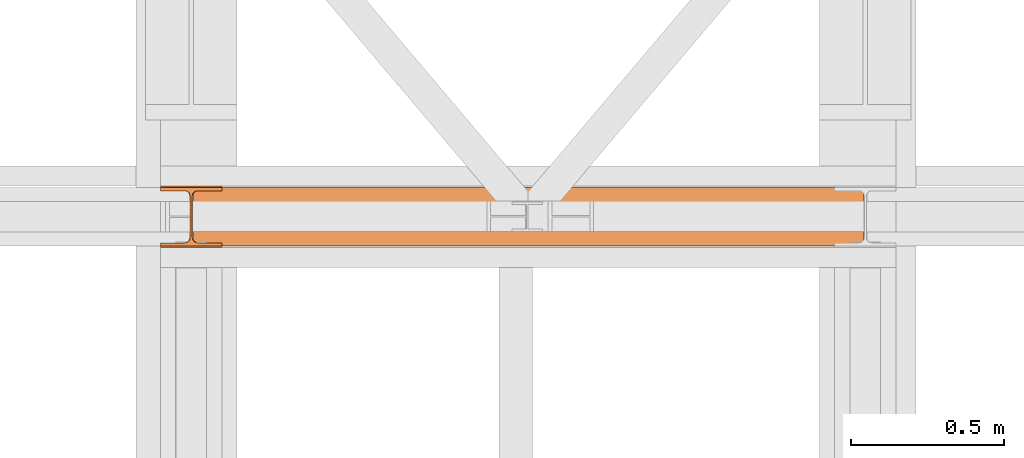
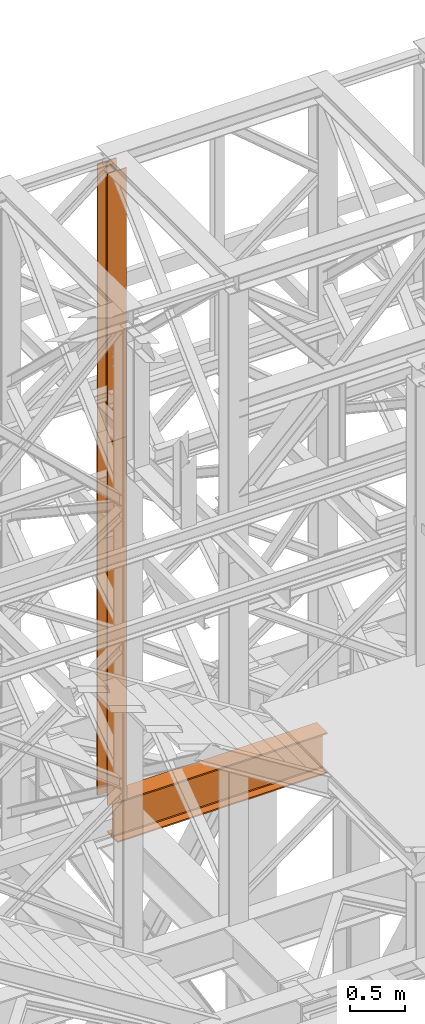
# One storey, part 118 of 208: 3 proxies.
"""IFC2X3 building model written with IfcOpenShell, lengths in millimetres."""

from ifc_helpers import new_model, entity, si_unit, converted_unit, frame, origin, origin_with_axes, place, context, subcontext, project, spatial, faceted_brep, element, save


model = new_model("IFC2X3")

# Units and contexts
model_context = context("Model", 3, precision=1e-05, world=origin())
plan_context = context("Plan", 3, precision=1e-05, world=origin())
body_context = subcontext(model_context, "Body", "Model", "MODEL_VIEW")
ifc_project = project(units=[si_unit("LENGTHUNIT", "METRE", prefix="MILLI"), converted_unit("PLANEANGLEUNIT", "DEGREE", entity("IfcPlaneAngleMeasure", 0.0174532925199433), si_unit("PLANEANGLEUNIT", "RADIAN"), dimensions=[0, 0, 0, 0, 0, 0, 0]), si_unit("AREAUNIT", "SQUARE_METRE"), si_unit("VOLUMEUNIT", "CUBIC_METRE")], contexts=[model_context, plan_context])

# Building, storey
building_placement = place(None, origin())
building = spatial("IfcBuilding", under=ifc_project, at=building_placement, CompositionType="COMPLEX")
storey_placement = place(building_placement, origin_with_axes())
storey = spatial("IfcBuildingStorey", under=building, at=storey_placement, Name="Geschoss", CompositionType="ELEMENT")

# Proxies
proxy_1_placement = place(storey_placement, frame((-0.7450314191753478, -13857.57439657637, 4834.989987483023), z_axis=(0.0, 0.0, 1.0), x_axis=(1.0, 0.0, 0.0)))
element("IfcBuildingElementProxy", 1, at=proxy_1_placement, inside=storey, context=body_context, shape_type="Brep", body=[
    faceted_brep([(2188.009999895692, 0.01000000000021828, 450.0100178813937), (2188.009999895692, 190.0100125169756, 450.0100178813937), (2188.009999895692, 190.0100125169756, 435.4100240564349), (2188.009999895692, 120.7100073045494, 435.4100091552737), (2188.009999895692, 109.841562265754, 433.2347078418734), (2188.009999895692, 101.8853126263621, 425.2784563398363), (2188.009999895692, 99.71000619068764, 414.4100113010409), (2188.009999895692, 99.71000619068764, 35.60999167919181), (2188.009999895692, 101.8853126263621, 24.74154664039634), (2188.009999895692, 109.841562265754, 16.78529513835929), (2188.009999895692, 120.7100073045494, 14.60999382495902), (2188.009999895692, 190.0100125169756, 14.60999382495902), (2188.009999895692, 190.0100125169756, 0.01000000000021828), (2188.009999895692, 0.01000000000021828, 0.01000000000021828), (2188.009999895692, 0.01000000000021828, 14.60999382495902), (2188.009999895692, 69.3100052124264, 14.60999382495902), (2188.009999895692, 80.17845025122188, 16.78529513835929), (2188.009999895692, 88.13469989061377, 24.74154664039634), (2188.009999895692, 90.3100063262882, 35.60999167919181), (2188.009999895692, 90.3100063262882, 414.4100113010409), (2188.009999895692, 88.13469989061377, 425.2784563398363), (2188.009999895692, 80.17845025122188, 433.2347078418734), (2188.009999895692, 69.3100052124264, 435.4100091552737), (2188.009999895692, 0.01000000000021828, 435.4100240564349), (2188.009999895692, 190.0100125169756, 450.0100178813937), (2188.009999895692, 0.01000000000021828, 450.0100178813937), (0.009999999999990905, 0.01000000000021828, 450.0100178813937), (0.009999999999990905, 190.0100125169756, 450.0100178813937), (2188.009999895692, 190.0100125169756, 435.4100240564349), (2188.009999895692, 190.0100125169756, 450.0100178813937), (0.009999999999990905, 190.0100125169756, 450.0100178813937), (0.009999999999990905, 190.0100125169756, 435.4100240564349), (2188.009999895692, 120.7100073045494, 435.4100091552737), (2188.009999895692, 190.0100125169756, 435.4100240564349), (0.009999999999990905, 190.0100125169756, 435.4100240564349), (0.009999999999990905, 120.7100073045494, 435.4100091552737), (2188.009999895692, 109.841562265754, 433.2347078418734), (2188.009999895692, 120.7100073045494, 435.4100091552737), (0.009999999999990905, 120.7100073045494, 435.4100091552737), (0.009999999999990905, 109.841562265754, 433.2347078418734), (2188.009999895692, 101.8853126263621, 425.2784563398363), (2188.009999895692, 109.841562265754, 433.2347078418734), (0.009999999999990905, 109.841562265754, 433.2347078418734), (0.009999999999990905, 101.8853126263621, 425.2784563398363), (2188.009999895692, 99.71000619068764, 414.4100113010409), (2188.009999895692, 101.8853126263621, 425.2784563398363), (0.009999999999990905, 101.8853126263621, 425.2784563398363), (0.009999999999990905, 99.71000619068764, 414.4100113010409), (2188.009999895692, 99.71000619068764, 35.60999167919181), (2188.009999895692, 99.71000619068764, 414.4100113010409), (0.009999999999990905, 99.71000619068764, 414.4100113010409), (0.009999999999990905, 99.71000619068764, 35.60999167919181), (2188.009999895692, 101.8853126263621, 24.74154664039634), (2188.009999895692, 99.71000619068764, 35.60999167919181), (0.009999999999990905, 99.71000619068764, 35.60999167919181), (0.009999999999990905, 101.8853126263621, 24.74154664039634), (2188.009999895692, 109.841562265754, 16.78529513835929), (2188.009999895692, 101.8853126263621, 24.74154664039634), (0.009999999999990905, 101.8853126263621, 24.74154664039634), (0.009999999999990905, 109.841562265754, 16.78529513835929), (2188.009999895692, 120.7100073045494, 14.60999382495902), (2188.009999895692, 109.841562265754, 16.78529513835929), (0.009999999999990905, 109.841562265754, 16.78529513835929), (0.009999999999990905, 120.7100073045494, 14.60999382495902), (2188.009999895692, 190.0100125169756, 14.60999382495902), (2188.009999895692, 120.7100073045494, 14.60999382495902), (0.009999999999990905, 120.7100073045494, 14.60999382495902), (0.009999999999990905, 190.0100125169756, 14.60999382495902), (2188.009999895692, 190.0100125169756, 0.01000000000021828), (2188.009999895692, 190.0100125169756, 14.60999382495902), (0.009999999999990905, 190.0100125169756, 14.60999382495902), (0.009999999999990905, 190.0100125169756, 0.01000000000021828), (2188.009999895692, 0.01000000000021828, 0.01000000000021828), (2188.009999895692, 190.0100125169756, 0.01000000000021828), (0.009999999999990905, 190.0100125169756, 0.01000000000021828), (0.009999999999990905, 0.01000000000021828, 0.01000000000021828), (2188.009999895692, 0.01000000000021828, 14.60999382495902), (2188.009999895692, 0.01000000000021828, 0.01000000000021828), (0.009999999999990905, 0.01000000000021828, 0.01000000000021828), (0.009999999999990905, 0.01000000000021828, 14.60999382495902), (2188.009999895692, 69.3100052124264, 14.60999382495902), (2188.009999895692, 0.01000000000021828, 14.60999382495902), (0.009999999999990905, 0.01000000000021828, 14.60999382495902), (0.009999999999990905, 69.3100052124264, 14.60999382495902), (2188.009999895692, 80.17845025122188, 16.78529513835929), (2188.009999895692, 69.3100052124264, 14.60999382495902), (0.009999999999990905, 69.3100052124264, 14.60999382495902), (0.009999999999990905, 80.17845025122188, 16.78529513835929), (2188.009999895692, 88.13469989061377, 24.74154664039634), (2188.009999895692, 80.17845025122188, 16.78529513835929), (0.009999999999990905, 80.17845025122188, 16.78529513835929), (0.009999999999990905, 88.13469989061377, 24.74154664039634), (2188.009999895692, 90.3100063262882, 35.60999167919181), (2188.009999895692, 88.13469989061377, 24.74154664039634), (0.009999999999990905, 88.13469989061377, 24.74154664039634), (0.009999999999990905, 90.3100063262882, 35.60999167919181), (2188.009999895692, 90.3100063262882, 414.4100113010409), (2188.009999895692, 90.3100063262882, 35.60999167919181), (0.009999999999990905, 90.3100063262882, 35.60999167919181), (0.009999999999990905, 90.3100063262882, 414.4100113010409), (2188.009999895692, 88.13469989061377, 425.2784563398363), (2188.009999895692, 90.3100063262882, 414.4100113010409), (0.009999999999990905, 90.3100063262882, 414.4100113010409), (0.009999999999990905, 88.13469989061377, 425.2784563398363), (2188.009999895692, 80.17845025122188, 433.2347078418734), (2188.009999895692, 88.13469989061377, 425.2784563398363), (0.009999999999990905, 88.13469989061377, 425.2784563398363), (0.009999999999990905, 80.17845025122188, 433.2347078418734), (2188.009999895692, 69.3100052124264, 435.4100091552737), (2188.009999895692, 80.17845025122188, 433.2347078418734), (0.009999999999990905, 80.17845025122188, 433.2347078418734), (0.009999999999990905, 69.3100052124264, 435.4100091552737), (2188.009999895692, 0.01000000000021828, 435.4100240564349), (2188.009999895692, 69.3100052124264, 435.4100091552737), (0.009999999999990905, 69.3100052124264, 435.4100091552737), (0.009999999999990905, 0.01000000000021828, 435.4100240564349), (2188.009999895692, 0.01000000000021828, 450.0100178813937), (2188.009999895692, 0.01000000000021828, 435.4100240564349), (0.009999999999990905, 0.01000000000021828, 435.4100240564349), (0.009999999999990905, 0.01000000000021828, 450.0100178813937), (0.009999999999990905, 0.01000000000021828, 450.0100178813937), (0.009999999999990905, 0.01000000000021828, 435.4100240564349), (0.009999999999990905, 69.3100052124264, 435.4100091552737), (0.009999999999990905, 80.17845025122188, 433.2347078418734), (0.009999999999990905, 88.13469989061377, 425.2784563398363), (0.009999999999990905, 90.3100063262882, 414.4100113010409), (0.009999999999990905, 90.3100063262882, 35.60999167919181), (0.009999999999990905, 88.13469989061377, 24.74154664039634), (0.009999999999990905, 80.17845025122188, 16.78529513835929), (0.009999999999990905, 69.3100052124264, 14.60999382495902), (0.009999999999990905, 0.01000000000021828, 14.60999382495902), (0.009999999999990905, 0.01000000000021828, 0.01000000000021828), (0.009999999999990905, 190.0100125169756, 0.01000000000021828), (0.009999999999990905, 190.0100125169756, 14.60999382495902), (0.009999999999990905, 120.7100073045494, 14.60999382495902), (0.009999999999990905, 109.841562265754, 16.78529513835929), (0.009999999999990905, 101.8853126263621, 24.74154664039634), (0.009999999999990905, 99.71000619068764, 35.60999167919181), (0.009999999999990905, 99.71000619068764, 414.4100113010409), (0.009999999999990905, 101.8853126263621, 425.2784563398363), (0.009999999999990905, 109.841562265754, 433.2347078418734), (0.009999999999990905, 120.7100073045494, 435.4100091552737), (0.009999999999990905, 190.0100125169756, 435.4100240564349), (0.009999999999990905, 190.0100125169756, 450.0100178813937)], [[[0, 1, 2, 3, 4, 5, 6, 7, 8, 9, 10, 11, 12, 13, 14, 15, 16, 17, 18, 19, 20, 21, 22, 23]], [[24, 25, 26, 27]], [[28, 29, 30, 31]], [[32, 33, 34, 35]], [[36, 37, 38, 39]], [[40, 41, 42, 43]], [[44, 45, 46, 47]], [[48, 49, 50, 51]], [[52, 53, 54, 55]], [[56, 57, 58, 59]], [[60, 61, 62, 63]], [[64, 65, 66, 67]], [[68, 69, 70, 71]], [[72, 73, 74, 75]], [[76, 77, 78, 79]], [[80, 81, 82, 83]], [[84, 85, 86, 87]], [[88, 89, 90, 91]], [[92, 93, 94, 95]], [[96, 97, 98, 99]], [[100, 101, 102, 103]], [[104, 105, 106, 107]], [[108, 109, 110, 111]], [[112, 113, 114, 115]], [[116, 117, 118, 119]], [[120, 121, 122, 123, 124, 125, 126, 127, 128, 129, 130, 131, 132, 133, 134, 135, 136, 137, 138, 139, 140, 141, 142, 143]]], orient=[[False], [False], [False], [False], [False], [False], [False], [False], [False], [False], [False], [False], [False], [False], [False], [False], [False], [False], [False], [False], [False], [False], [False], [False], [False], [False]]),
])
proxy_2_placement = place(storey_placement, frame((-106.7450329614492, -13857.57439657637, 9284.990005364414), z_axis=(0.0, 0.0, 1.0), x_axis=(1.0, 0.0, 0.0)))
element("IfcBuildingElementProxy", 2, at=proxy_2_placement, inside=storey, context=body_context, shape_type="Brep", body=[
    faceted_brep([(0.01000000000000512, 190.0100125169756, 2965.010053329394), (200.0100029802322, 190.0100125169756, 2965.010053329394), (200.0100029802322, 180.0100146031382, 2965.010053329394), (121.2600035762787, 180.0100071525576, 2965.010053329394), (111.9441915473342, 178.1454621052744, 2965.010053329394), (105.1245498640835, 171.3258190250399, 2965.010053329394), (103.2600015571714, 162.010007927418, 2965.010053329394), (103.2600015571714, 28.00999713897727, 2965.010053329394), (105.1245498640835, 18.69418604135535, 2965.010053329394), (111.9441915473342, 11.87454296112082, 2965.010053329394), (121.2600035762787, 10.00999791383765, 2965.010053329394), (200.0100029802322, 10.00999791383765, 2965.010053329394), (200.0100029802322, 0.01000000000021828, 2965.010053329394), (0.01000000000000512, 0.01000000000021828, 2965.010053329394), (0.01000000000000512, 10.00999791383765, 2965.010053329394), (78.75999940395356, 10.00999791383765, 2965.010053329394), (88.07581143289805, 11.87454296112082, 2965.010053329394), (94.89545311614872, 18.69418604135535, 2965.010053329394), (96.7600014230609, 28.00999713897727, 2965.010053329394), (96.7600014230609, 162.010007927418, 2965.010053329394), (94.89545311614872, 171.3258190250399, 2965.010053329394), (88.07581143289805, 178.1454621052744, 2965.010053329394), (78.75999940395356, 180.0100071525576, 2965.010053329394), (0.01000000000000512, 180.0100146031382, 2965.010053329394), (200.0100029802322, 190.0100125169756, 2965.010053329394), (0.01000000000000512, 190.0100125169756, 2965.010053329394), (0.01000000000000512, 190.0100125169756, 0.01000000000021828), (200.0100029802322, 190.0100125169756, 0.01000000000021828), (200.0100029802322, 180.0100146031382, 2965.010053329394), (200.0100029802322, 190.0100125169756, 2965.010053329394), (200.0100029802322, 190.0100125169756, 0.01000000000021828), (200.0100029802322, 180.0100146031382, 0.01000000000021828), (121.2600035762787, 180.0100071525576, 2965.010053329394), (200.0100029802322, 180.0100146031382, 2965.010053329394), (200.0100029802322, 180.0100146031382, 0.01000000000021828), (121.2600035762787, 180.0100071525576, 0.01000000000021828), (111.9441915473342, 178.1454621052744, 2965.010053329394), (121.2600035762787, 180.0100071525576, 2965.010053329394), (121.2600035762787, 180.0100071525576, 0.01000000000021828), (111.9441915473342, 178.1454621052744, 0.01000000000021828), (105.1245498640835, 171.3258190250399, 2965.010053329394), (111.9441915473342, 178.1454621052744, 2965.010053329394), (111.9441915473342, 178.1454621052744, 0.01000000000021828), (105.1245498640835, 171.3258190250399, 0.01000000000021828), (103.2600015571714, 162.010007927418, 2965.010053329394), (105.1245498640835, 171.3258190250399, 2965.010053329394), (105.1245498640835, 171.3258190250399, 0.01000000000021828), (103.2600015571714, 162.010007927418, 0.01000000000021828), (103.2600015571714, 28.00999713897727, 2965.010053329394), (103.2600015571714, 162.010007927418, 2965.010053329394), (103.2600015571714, 162.010007927418, 0.01000000000021828), (103.2600015571714, 28.00999713897727, 0.01000000000021828), (105.1245498640835, 18.69418604135535, 2965.010053329394), (103.2600015571714, 28.00999713897727, 2965.010053329394), (103.2600015571714, 28.00999713897727, 0.01000000000021828), (105.1245498640835, 18.69418604135535, 0.01000000000021828), (111.9441915473342, 11.87454296112082, 2965.010053329394), (105.1245498640835, 18.69418604135535, 2965.010053329394), (105.1245498640835, 18.69418604135535, 0.01000000000021828), (111.9441915473342, 11.87454296112082, 0.01000000000021828), (121.2600035762787, 10.00999791383765, 2965.010053329394), (111.9441915473342, 11.87454296112082, 2965.010053329394), (111.9441915473342, 11.87454296112082, 0.01000000000021828), (121.2600035762787, 10.00999791383765, 0.01000000000021828), (200.0100029802322, 10.00999791383765, 2965.010053329394), (121.2600035762787, 10.00999791383765, 2965.010053329394), (121.2600035762787, 10.00999791383765, 0.01000000000021828), (200.0100029802322, 10.00999791383765, 0.01000000000021828), (200.0100029802322, 0.01000000000021828, 2965.010053329394), (200.0100029802322, 10.00999791383765, 2965.010053329394), (200.0100029802322, 10.00999791383765, 0.01000000000021828), (200.0100029802322, 0.01000000000021828, 0.01000000000021828), (0.01000000000000512, 0.01000000000021828, 2965.010053329394), (200.0100029802322, 0.01000000000021828, 2965.010053329394), (200.0100029802322, 0.01000000000021828, 0.01000000000021828), (0.01000000000000512, 0.01000000000021828, 0.01000000000021828), (0.01000000000000512, 10.00999791383765, 2965.010053329394), (0.01000000000000512, 0.01000000000021828, 2965.010053329394), (0.01000000000000512, 0.01000000000021828, 0.01000000000021828), (0.01000000000000512, 10.00999791383765, 0.01000000000021828), (78.75999940395356, 10.00999791383765, 2965.010053329394), (0.01000000000000512, 10.00999791383765, 2965.010053329394), (0.01000000000000512, 10.00999791383765, 0.01000000000021828), (78.75999940395356, 10.00999791383765, 0.01000000000021828), (88.07581143289805, 11.87454296112082, 2965.010053329394), (78.75999940395356, 10.00999791383765, 2965.010053329394), (78.75999940395356, 10.00999791383765, 0.01000000000021828), (88.07581143289805, 11.87454296112082, 0.01000000000021828), (94.89545311614872, 18.69418604135535, 2965.010053329394), (88.07581143289805, 11.87454296112082, 2965.010053329394), (88.07581143289805, 11.87454296112082, 0.01000000000021828), (94.89545311614872, 18.69418604135535, 0.01000000000021828), (96.7600014230609, 28.00999713897727, 2965.010053329394), (94.89545311614872, 18.69418604135535, 2965.010053329394), (94.89545311614872, 18.69418604135535, 0.01000000000021828), (96.7600014230609, 28.00999713897727, 0.01000000000021828), (96.7600014230609, 162.010007927418, 2965.010053329394), (96.7600014230609, 28.00999713897727, 2965.010053329394), (96.7600014230609, 28.00999713897727, 0.01000000000021828), (96.7600014230609, 162.010007927418, 0.01000000000021828), (94.89545311614872, 171.3258190250399, 2965.010053329394), (96.7600014230609, 162.010007927418, 2965.010053329394), (96.7600014230609, 162.010007927418, 0.01000000000021828), (94.89545311614872, 171.3258190250399, 0.01000000000021828), (88.07581143289805, 178.1454621052744, 2965.010053329394), (94.89545311614872, 171.3258190250399, 2965.010053329394), (94.89545311614872, 171.3258190250399, 0.01000000000021828), (88.07581143289805, 178.1454621052744, 0.01000000000021828), (78.75999940395356, 180.0100071525576, 2965.010053329394), (88.07581143289805, 178.1454621052744, 2965.010053329394), (88.07581143289805, 178.1454621052744, 0.01000000000021828), (78.75999940395356, 180.0100071525576, 0.01000000000021828), (0.01000000000000512, 180.0100146031382, 2965.010053329394), (78.75999940395356, 180.0100071525576, 2965.010053329394), (78.75999940395356, 180.0100071525576, 0.01000000000021828), (0.01000000000000512, 180.0100146031382, 0.01000000000021828), (0.01000000000000512, 190.0100125169756, 2965.010053329394), (0.01000000000000512, 180.0100146031382, 2965.010053329394), (0.01000000000000512, 180.0100146031382, 0.01000000000021828), (0.01000000000000512, 190.0100125169756, 0.01000000000021828), (0.01000000000000512, 190.0100125169756, 0.01000000000021828), (0.01000000000000512, 180.0100146031382, 0.01000000000021828), (78.75999940395356, 180.0100071525576, 0.01000000000021828), (88.07581143289805, 178.1454621052744, 0.01000000000021828), (94.89545311614872, 171.3258190250399, 0.01000000000021828), (96.7600014230609, 162.010007927418, 0.01000000000021828), (96.7600014230609, 28.00999713897727, 0.01000000000021828), (94.89545311614872, 18.69418604135535, 0.01000000000021828), (88.07581143289805, 11.87454296112082, 0.01000000000021828), (78.75999940395356, 10.00999791383765, 0.01000000000021828), (0.01000000000000512, 10.00999791383765, 0.01000000000021828), (0.01000000000000512, 0.01000000000021828, 0.01000000000021828), (200.0100029802322, 0.01000000000021828, 0.01000000000021828), (200.0100029802322, 10.00999791383765, 0.01000000000021828), (121.2600035762787, 10.00999791383765, 0.01000000000021828), (111.9441915473342, 11.87454296112082, 0.01000000000021828), (105.1245498640835, 18.69418604135535, 0.01000000000021828), (103.2600015571714, 28.00999713897727, 0.01000000000021828), (103.2600015571714, 162.010007927418, 0.01000000000021828), (105.1245498640835, 171.3258190250399, 0.01000000000021828), (111.9441915473342, 178.1454621052744, 0.01000000000021828), (121.2600035762787, 180.0100071525576, 0.01000000000021828), (200.0100029802322, 180.0100146031382, 0.01000000000021828), (200.0100029802322, 190.0100125169756, 0.01000000000021828)], [[[0, 1, 2, 3, 4, 5, 6, 7, 8, 9, 10, 11, 12, 13, 14, 15, 16, 17, 18, 19, 20, 21, 22, 23]], [[24, 25, 26, 27]], [[28, 29, 30, 31]], [[32, 33, 34, 35]], [[36, 37, 38, 39]], [[40, 41, 42, 43]], [[44, 45, 46, 47]], [[48, 49, 50, 51]], [[52, 53, 54, 55]], [[56, 57, 58, 59]], [[60, 61, 62, 63]], [[64, 65, 66, 67]], [[68, 69, 70, 71]], [[72, 73, 74, 75]], [[76, 77, 78, 79]], [[80, 81, 82, 83]], [[84, 85, 86, 87]], [[88, 89, 90, 91]], [[92, 93, 94, 95]], [[96, 97, 98, 99]], [[100, 101, 102, 103]], [[104, 105, 106, 107]], [[108, 109, 110, 111]], [[112, 113, 114, 115]], [[116, 117, 118, 119]], [[120, 121, 122, 123, 124, 125, 126, 127, 128, 129, 130, 131, 132, 133, 134, 135, 136, 137, 138, 139, 140, 141, 142, 143]]], orient=[[False], [False], [False], [False], [False], [False], [False], [False], [False], [False], [False], [False], [False], [False], [False], [False], [False], [False], [False], [False], [False], [False], [False], [False], [False], [False]]),
])
proxy_3_placement = place(storey_placement, frame((-106.7450299812169, -13862.57439031789, 5284.990005364414), z_axis=(0.0, 0.0, 1.0), x_axis=(1.0, 0.0, 0.0)))
element("IfcBuildingElementProxy", 3, at=proxy_3_placement, inside=storey, Name="3D Element", context=body_context, shape_type="Brep", body=[
    faceted_brep([(0.01000000000000512, 15.01000000000022, 0.01000000000021828), (0.01000000000000512, 0.01000000000021828, 0.01000000000021828), (200.01, 0.01000000000021828, 0.01000000000021828), (200.01, 15.01000000000022, 0.01000000000021828), (122.51, 15.01000000000022, 0.01000000000021828), (116.9477129694262, 15.8910440384916, 0.01000000000021828), (111.9298832894654, 18.44771635773031, 0.01000000000021828), (107.9477163577319, 22.42988328946558, 0.01000000000021828), (105.3910440384932, 27.44771296942599, 0.01000000000021828), (104.51, 33.01000000000022, 0.01000000000021828), (104.51, 167.0100000000002, 0.01000000000021828), (105.6055874411056, 172.9933586889038, 0.01000000000021828), (107.9477163577319, 177.5901167105349, 0.01000000000021828), (111.9298832894654, 181.5722836422665, 0.01000000000021828), (116.9477129694262, 184.1289559615052, 0.01000000000021828), (122.51, 185.0100000000002, 0.01000000000021828), (200.01, 185.0100000000002, 0.01000000000021828), (200.01, 200.0100000000002, 0.01000000000021828), (0.01000000000000512, 200.0100000000002, 0.01000000000021828), (0.01000000000000512, 185.0100000000002, 0.01000000000021828), (77.51, 185.0100000000002, 0.01000000000021828), (83.07228703057332, 184.1289559615052, 0.01000000000021828), (88.09011671053419, 181.5722836422665, 0.01000000000021828), (92.07228364226764, 177.5901167105349, 0.01000000000021828), (94.62895596150635, 172.5722870305744, 0.01000000000021828), (95.51, 167.0100000000002, 0.01000000000021828), (95.51, 33.01000000000022, 0.01000000000021828), (94.62895596150635, 27.44771296942599, 0.01000000000021828), (92.07228364226764, 22.42988328946558, 0.01000000000021828), (88.09011671053419, 18.44771635773031, 0.01000000000021828), (83.07228703057332, 15.8910440384916, 0.01000000000021828), (77.51, 15.01000000000022, 0.01000000000021828), (0.01000000000000512, 0.01000000000021828, 0.01000000000021828), (0.01000000000000512, 15.01000000000022, 0.01000000000021828), (0.01000000000000512, 15.01000000000022, 4000.01), (0.01000000000000512, 0.01000000000021828, 4000.01), (200.01, 0.01000000000021828, 0.01000000000021828), (0.01000000000000512, 0.01000000000021828, 0.01000000000021828), (0.01000000000000512, 0.01000000000021828, 4000.01), (200.01, 0.01000000000021828, 4000.01), (200.01, 15.01000000000022, 0.01000000000021828), (200.01, 0.01000000000021828, 0.01000000000021828), (200.01, 0.01000000000021828, 4000.01), (200.01, 15.01000000000022, 4000.01), (122.51, 15.01000000000022, 0.01000000000021828), (200.01, 15.01000000000022, 0.01000000000021828), (200.01, 15.01000000000022, 4000.01), (122.51, 15.01000000000022, 4000.01), (116.9477129694262, 15.8910440384916, 0.01000000000021828), (122.51, 15.01000000000022, 0.01000000000021828), (122.51, 15.01000000000022, 4000.01), (116.9477129694262, 15.8910440384916, 4000.01), (111.9298832894654, 18.44771635773031, 0.01000000000021828), (116.9477129694262, 15.8910440384916, 0.01000000000021828), (116.9477129694262, 15.8910440384916, 4000.01), (111.9298832894654, 18.44771635773031, 4000.01), (107.9477163577319, 22.42988328946558, 0.01000000000021828), (111.9298832894654, 18.44771635773031, 0.01000000000021828), (111.9298832894654, 18.44771635773031, 4000.01), (107.9477163577319, 22.42988328946558, 4000.01), (105.3910440384932, 27.44771296942599, 0.01000000000021828), (107.9477163577319, 22.42988328946558, 0.01000000000021828), (107.9477163577319, 22.42988328946558, 4000.01), (105.3910440384932, 27.44771296942599, 4000.01), (104.51, 33.01000000000022, 0.01000000000021828), (105.3910440384932, 27.44771296942599, 0.01000000000021828), (105.3910440384932, 27.44771296942599, 4000.01), (104.51, 33.01000000000022, 4000.01), (104.51, 167.0100000000002, 0.01000000000021828), (104.51, 33.01000000000022, 0.01000000000021828), (104.51, 33.01000000000022, 4000.01), (104.51, 167.0100000000002, 4000.01), (105.6055874411056, 172.9933586889038, 0.01000000000021828), (104.51, 167.0100000000002, 0.01000000000021828), (104.51, 167.0100000000002, 4000.01), (105.6055874411056, 172.9933586889038, 4000.01), (107.9477163577319, 177.5901167105349, 0.01000000000021828), (105.6055874411056, 172.9933586889038, 0.01000000000021828), (105.6055874411056, 172.9933586889038, 4000.01), (107.9477163577319, 177.5901167105349, 4000.01), (111.9298832894654, 181.5722836422665, 0.01000000000021828), (107.9477163577319, 177.5901167105349, 0.01000000000021828), (107.9477163577319, 177.5901167105349, 4000.01), (111.9298832894654, 181.5722836422665, 4000.01), (116.9477129694262, 184.1289559615052, 0.01000000000021828), (111.9298832894654, 181.5722836422665, 0.01000000000021828), (111.9298832894654, 181.5722836422665, 4000.01), (116.9477129694262, 184.1289559615052, 4000.01), (122.51, 185.0100000000002, 0.01000000000021828), (116.9477129694262, 184.1289559615052, 0.01000000000021828), (116.9477129694262, 184.1289559615052, 4000.01), (122.51, 185.0100000000002, 4000.01), (200.01, 185.0100000000002, 0.01000000000021828), (122.51, 185.0100000000002, 0.01000000000021828), (122.51, 185.0100000000002, 4000.01), (200.01, 185.0100000000002, 4000.01), (200.01, 200.0100000000002, 0.01000000000021828), (200.01, 185.0100000000002, 0.01000000000021828), (200.01, 185.0100000000002, 4000.01), (200.01, 200.0100000000002, 4000.01), (0.01000000000000512, 200.0100000000002, 0.01000000000021828), (200.01, 200.0100000000002, 0.01000000000021828), (200.01, 200.0100000000002, 4000.01), (0.01000000000000512, 200.0100000000002, 4000.01), (0.01000000000000512, 185.0100000000002, 0.01000000000021828), (0.01000000000000512, 200.0100000000002, 0.01000000000021828), (0.01000000000000512, 200.0100000000002, 4000.01), (0.01000000000000512, 185.0100000000002, 4000.01), (77.51, 185.0100000000002, 0.01000000000021828), (0.01000000000000512, 185.0100000000002, 0.01000000000021828), (0.01000000000000512, 185.0100000000002, 4000.01), (77.51, 185.0100000000002, 4000.01), (83.07228703057332, 184.1289559615052, 0.01000000000021828), (77.51, 185.0100000000002, 0.01000000000021828), (77.51, 185.0100000000002, 4000.01), (83.07228703057332, 184.1289559615052, 4000.01), (88.09011671053419, 181.5722836422665, 0.01000000000021828), (83.07228703057332, 184.1289559615052, 0.01000000000021828), (83.07228703057332, 184.1289559615052, 4000.01), (88.09011671053419, 181.5722836422665, 4000.01), (92.07228364226764, 177.5901167105349, 0.01000000000021828), (88.09011671053419, 181.5722836422665, 0.01000000000021828), (88.09011671053419, 181.5722836422665, 4000.01), (92.07228364226764, 177.5901167105349, 4000.01), (94.62895596150635, 172.5722870305744, 0.01000000000021828), (92.07228364226764, 177.5901167105349, 0.01000000000021828), (92.07228364226764, 177.5901167105349, 4000.01), (94.62895596150635, 172.5722870305744, 4000.01), (95.51, 167.0100000000002, 0.01000000000021828), (94.62895596150635, 172.5722870305744, 0.01000000000021828), (94.62895596150635, 172.5722870305744, 4000.01), (95.51, 167.0100000000002, 4000.01), (95.51, 33.01000000000022, 0.01000000000021828), (95.51, 167.0100000000002, 0.01000000000021828), (95.51, 167.0100000000002, 4000.01), (95.51, 33.01000000000022, 4000.01), (94.62895596150635, 27.44771296942599, 0.01000000000021828), (95.51, 33.01000000000022, 0.01000000000021828), (95.51, 33.01000000000022, 4000.01), (94.62895596150635, 27.44771296942599, 4000.01), (92.07228364226764, 22.42988328946558, 0.01000000000021828), (94.62895596150635, 27.44771296942599, 0.01000000000021828), (94.62895596150635, 27.44771296942599, 4000.01), (92.07228364226764, 22.42988328946558, 4000.01), (88.09011671053419, 18.44771635773031, 0.01000000000021828), (92.07228364226764, 22.42988328946558, 0.01000000000021828), (92.07228364226764, 22.42988328946558, 4000.01), (88.09011671053419, 18.44771635773031, 4000.01), (83.07228703057332, 15.8910440384916, 0.01000000000021828), (88.09011671053419, 18.44771635773031, 0.01000000000021828), (88.09011671053419, 18.44771635773031, 4000.01), (83.07228703057332, 15.8910440384916, 4000.01), (77.51, 15.01000000000022, 0.01000000000021828), (83.07228703057332, 15.8910440384916, 0.01000000000021828), (83.07228703057332, 15.8910440384916, 4000.01), (77.51, 15.01000000000022, 4000.01), (0.01000000000000512, 15.01000000000022, 0.01000000000021828), (77.51, 15.01000000000022, 0.01000000000021828), (77.51, 15.01000000000022, 4000.01), (0.01000000000000512, 15.01000000000022, 4000.01), (0.01000000000000512, 15.01000000000022, 4000.01), (77.51, 15.01000000000022, 4000.01), (83.07228703057332, 15.8910440384916, 4000.01), (88.09011671053419, 18.44771635773031, 4000.01), (92.07228364226764, 22.42988328946558, 4000.01), (94.62895596150635, 27.44771296942599, 4000.01), (95.51, 33.01000000000022, 4000.01), (95.51, 167.0100000000002, 4000.01), (94.62895596150635, 172.5722870305744, 4000.01), (92.07228364226764, 177.5901167105349, 4000.01), (88.09011671053419, 181.5722836422665, 4000.01), (83.07228703057332, 184.1289559615052, 4000.01), (77.51, 185.0100000000002, 4000.01), (0.01000000000000512, 185.0100000000002, 4000.01), (0.01000000000000512, 200.0100000000002, 4000.01), (200.01, 200.0100000000002, 4000.01), (200.01, 185.0100000000002, 4000.01), (122.51, 185.0100000000002, 4000.01), (116.9477129694262, 184.1289559615052, 4000.01), (111.9298832894654, 181.5722836422665, 4000.01), (107.9477163577319, 177.5901167105349, 4000.01), (105.6055874411056, 172.9933586889038, 4000.01), (104.51, 167.0100000000002, 4000.01), (104.51, 33.01000000000022, 4000.01), (105.3910440384932, 27.44771296942599, 4000.01), (107.9477163577319, 22.42988328946558, 4000.01), (111.9298832894654, 18.44771635773031, 4000.01), (116.9477129694262, 15.8910440384916, 4000.01), (122.51, 15.01000000000022, 4000.01), (200.01, 15.01000000000022, 4000.01), (200.01, 0.01000000000021828, 4000.01), (0.01000000000000512, 0.01000000000021828, 4000.01)], [[[0, 1, 2, 3, 4, 5, 6, 7, 8, 9, 10, 11, 12, 13, 14, 15, 16, 17, 18, 19, 20, 21, 22, 23, 24, 25, 26, 27, 28, 29, 30, 31]], [[32, 33, 34, 35]], [[36, 37, 38, 39]], [[40, 41, 42, 43]], [[44, 45, 46, 47]], [[48, 49, 50, 51]], [[52, 53, 54, 55]], [[56, 57, 58, 59]], [[60, 61, 62, 63]], [[64, 65, 66, 67]], [[68, 69, 70, 71]], [[72, 73, 74, 75]], [[76, 77, 78, 79]], [[80, 81, 82, 83]], [[84, 85, 86, 87]], [[88, 89, 90, 91]], [[92, 93, 94, 95]], [[96, 97, 98, 99]], [[100, 101, 102, 103]], [[104, 105, 106, 107]], [[108, 109, 110, 111]], [[112, 113, 114, 115]], [[116, 117, 118, 119]], [[120, 121, 122, 123]], [[124, 125, 126, 127]], [[128, 129, 130, 131]], [[132, 133, 134, 135]], [[136, 137, 138, 139]], [[140, 141, 142, 143]], [[144, 145, 146, 147]], [[148, 149, 150, 151]], [[152, 153, 154, 155]], [[156, 157, 158, 159]], [[160, 161, 162, 163, 164, 165, 166, 167, 168, 169, 170, 171, 172, 173, 174, 175, 176, 177, 178, 179, 180, 181, 182, 183, 184, 185, 186, 187, 188, 189, 190, 191]]], orient=[[False], [False], [False], [False], [False], [False], [False], [False], [False], [False], [False], [False], [False], [False], [False], [False], [False], [False], [False], [False], [False], [False], [False], [False], [False], [False], [False], [False], [False], [False], [False], [False], [False], [False]]),
])

save(model, "model.ifc")
